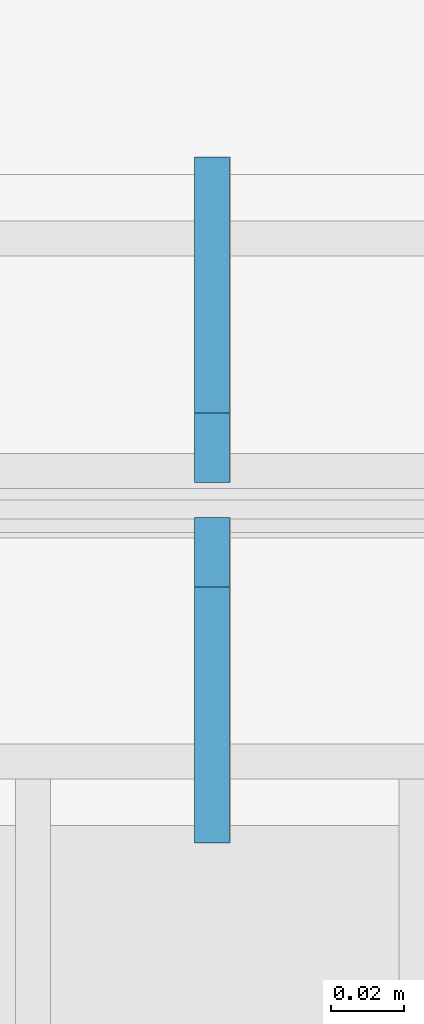
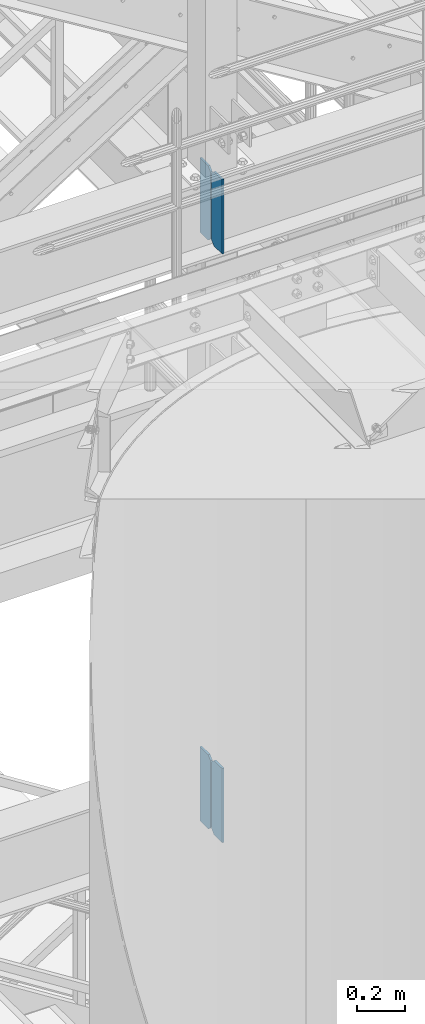
# One storey, part 1449 of 1876: 4 plates, 2 elements without a shape of their own.
"""IFC2X3 building model written with IfcOpenShell, lengths in millimetres."""

from ifc_helpers import new_model, si_unit, frame, origin_with_axes, place, context, subcontext, project, spatial, faceted_brep, material, type_object, element, aggregate, save


model = new_model("IFC2X3")

# Units and contexts
model_context = context("Model", 3, precision=1e-05, world=origin_with_axes())
body_context = subcontext(model_context, "Body", "Model", "MODEL_VIEW")
ifc_project = project(units=[si_unit("LENGTHUNIT", "METRE", prefix="MILLI"), si_unit("AREAUNIT", "SQUARE_METRE"), si_unit("VOLUMEUNIT", "CUBIC_METRE"), si_unit("MASSUNIT", "GRAM", prefix="KILO"), si_unit("TIMEUNIT", "SECOND"), si_unit("PLANEANGLEUNIT", "RADIAN"), si_unit("SOLIDANGLEUNIT", "STERADIAN"), si_unit("THERMODYNAMICTEMPERATUREUNIT", "DEGREE_CELSIUS"), si_unit("LUMINOUSINTENSITYUNIT", "LUMEN")], contexts=[model_context])

# Site, building, storey
site_placement = place(None, origin_with_axes())
site = spatial("IfcSite", under=ifc_project, at=site_placement, CompositionType="ELEMENT")
building_placement = place(site_placement, origin_with_axes())
building = spatial("IfcBuilding", under=site, at=building_placement, Name="Undefined", CompositionType="ELEMENT")
storey_placement = place(building_placement, origin_with_axes())
storey = spatial("IfcBuildingStorey", under=building, at=storey_placement, Name="Undefined", CompositionType="ELEMENT", Elevation=0.0)

# Assembly, plates
assembly_1_placement = place(storey_placement, origin_with_axes())
assembly_1 = element("IfcElementAssembly", 1, at=assembly_1_placement, inside=storey, Name="BEAM", AssemblyPlace="NOTDEFINED", PredefinedType="RIGID_FRAME")
ifc_material = material(Name="STEEL/A36")
plate_type = type_object("IfcPlateType", PredefinedType="NOTDEFINED")
plate_1_placement = place(assembly_1_placement, frame((5079.71425401922, -7205.6625, 7758.1125), z_axis=(0.0, 0.0, 1.0), x_axis=(0.0, 1.0, 0.0)))
plate_1 = element("IfcPlate", 2, at=plate_1_placement, type_object=plate_type, material=ifc_material, Name="PLATE", context=body_context, shape_type="Brep", body=[
    faceted_brep([(0.0, -4.76249999999982, 0.0), (0.0, -4.76250000000073, 381.0), (0.0, 4.76250000000073, 381.0), (0.0, 4.76249999999982, 0.0), (69.8500022888184, -4.76249999999982, 381.0), (69.8500022888184, 4.76249999999982, 381.0), (88.9000015258789, -4.76249999999982, 361.950000762939), (88.9000015258789, 4.76249999999982, 361.950000762939), (88.9000015258789, -4.76249999999982, 19.0499992370605), (88.9000015258789, 4.76249999999982, 19.0499992370605), (69.8500022888184, -4.76249999999982, 0.0), (69.8500022888184, 4.76249999999982, 0.0)], [[[0, 1, 2, 3]], [[1, 4, 5, 2]], [[4, 6, 7, 5]], [[6, 8, 9, 7]], [[8, 10, 11, 9]], [[10, 0, 3, 11]], [[5, 7, 9, 11, 3, 2]], [[10, 8, 6, 4, 1, 0]]]),
])
plate_2_placement = place(assembly_1_placement, frame((5079.71425401922, -7107.2375, 7758.1125), z_axis=(0.0, 0.0, 1.0), x_axis=(0.0, 1.0, 0.0)))
plate_2 = element("IfcPlate", 3, at=plate_2_placement, type_object=plate_type, material=ifc_material, Name="PLATE", context=body_context, shape_type="Brep", body=[
    faceted_brep([(0.0, -4.76249999999982, 19.0499992370605), (0.0, -4.76249999999982, 361.950000762939), (0.0, 4.76249999999982, 361.950000762939), (0.0, 4.76249999999982, 19.0499992370605), (19.0499992370605, -4.76249999999982, 381.0), (19.0499992370605, 4.76249999999982, 381.0), (88.9000015258789, -4.76249999999982, 381.0), (88.9000015258789, 4.76249999999982, 381.0), (88.9000015258789, -4.76249999999982, 0.0), (88.9000015258789, 4.76249999999982, 0.0), (19.0499992370605, -4.76249999999982, 0.0), (19.0499992370605, 4.76249999999982, 0.0)], [[[0, 1, 2, 3]], [[1, 4, 5, 2]], [[4, 6, 7, 5]], [[6, 8, 9, 7]], [[8, 10, 11, 9]], [[10, 0, 3, 11]], [[5, 7, 9, 11, 3, 2]], [[10, 8, 6, 4, 1, 0]]]),
])
aggregate(assembly_1, [plate_1, plate_2])

assembly_2_placement = place(storey_placement, origin_with_axes())
assembly_2 = element("IfcElementAssembly", 4, at=assembly_2_placement, inside=storey, Name="BEAM", AssemblyPlace="NOTDEFINED", PredefinedType="RIGID_FRAME")
plate_3_placement = place(assembly_2_placement, frame((5079.71425401922, -7205.6625, 4735.5125), z_axis=(0.0, 0.0, 1.0), x_axis=(0.0, 1.0, 0.0)))
plate_3 = element("IfcPlate", 5, at=plate_3_placement, type_object=plate_type, material=ifc_material, Name="PLATE", context=body_context, shape_type="Brep", body=[
    faceted_brep([(0.0, -4.76249999999982, 0.0), (0.0, -4.76250000000073, 381.0), (0.0, 4.76250000000073, 381.0), (0.0, 4.76249999999982, 0.0), (69.8500022888184, -4.76249999999982, 381.0), (69.8500022888184, 4.76249999999982, 381.0), (88.9000015258789, -4.76249999999982, 361.950000762939), (88.9000015258789, 4.76249999999982, 361.950000762939), (88.9000015258789, -4.76249999999982, 19.0499992370605), (88.9000015258789, 4.76249999999982, 19.0499992370605), (69.8500022888184, -4.76249999999982, 0.0), (69.8500022888184, 4.76249999999982, 0.0)], [[[0, 1, 2, 3]], [[1, 4, 5, 2]], [[4, 6, 7, 5]], [[6, 8, 9, 7]], [[8, 10, 11, 9]], [[10, 0, 3, 11]], [[5, 7, 9, 11, 3, 2]], [[10, 8, 6, 4, 1, 0]]]),
])
plate_4_placement = place(assembly_2_placement, frame((5079.71425401922, -7107.2375, 4735.5125), z_axis=(0.0, 0.0, 1.0), x_axis=(0.0, 1.0, 0.0)))
plate_4 = element("IfcPlate", 6, at=plate_4_placement, type_object=plate_type, material=ifc_material, Name="PLATE", context=body_context, shape_type="Brep", body=[
    faceted_brep([(0.0, -4.76249999999982, 19.0499992370605), (0.0, -4.76249999999982, 361.950000762939), (0.0, 4.76249999999982, 361.950000762939), (0.0, 4.76249999999982, 19.0499992370605), (19.0499992370605, -4.76249999999982, 381.0), (19.0499992370605, 4.76249999999982, 381.0), (88.9000015258789, -4.76249999999982, 381.0), (88.9000015258789, 4.76249999999982, 381.0), (88.9000015258789, -4.76249999999982, 0.0), (88.9000015258789, 4.76249999999982, 0.0), (19.0499992370605, -4.76249999999982, 0.0), (19.0499992370605, 4.76249999999982, 0.0)], [[[0, 1, 2, 3]], [[1, 4, 5, 2]], [[4, 6, 7, 5]], [[6, 8, 9, 7]], [[8, 10, 11, 9]], [[10, 0, 3, 11]], [[5, 7, 9, 11, 3, 2]], [[10, 8, 6, 4, 1, 0]]]),
])
aggregate(assembly_2, [plate_3, plate_4])

save(model, "model.ifc")
